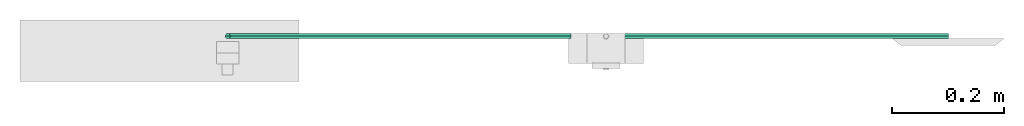
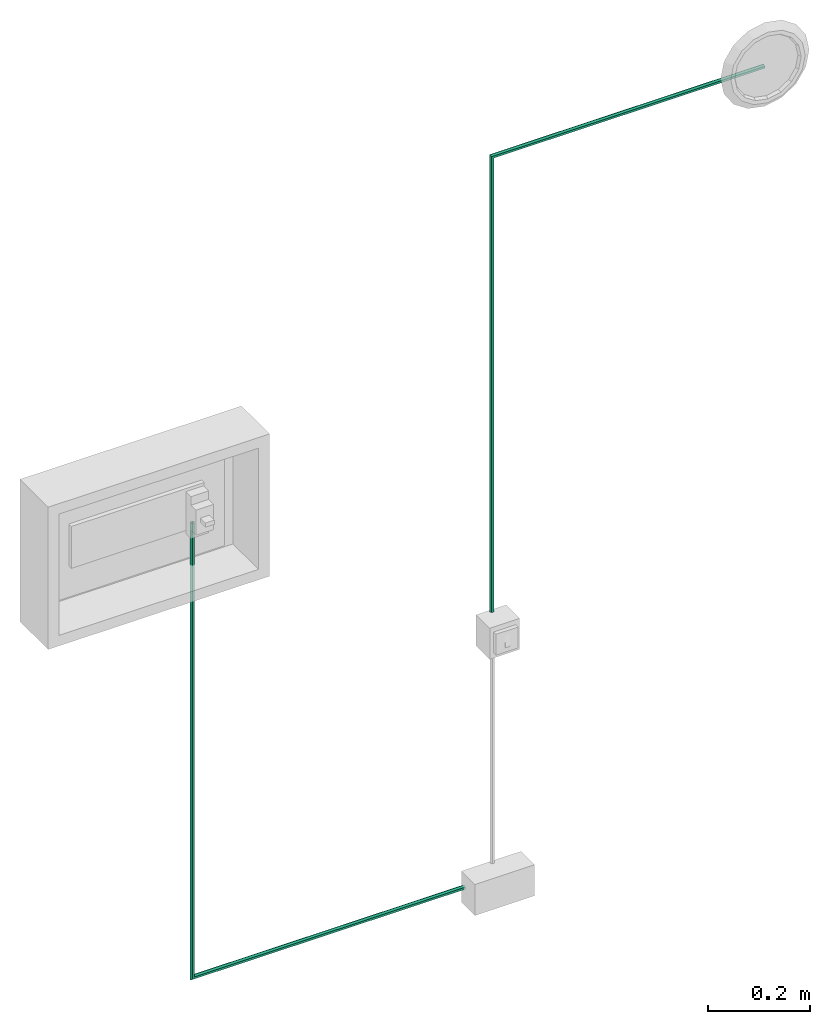
# One storey, part 2 of 4: 2 cable segments.
"""IFC4X3_ADD2 building model written with IfcOpenShell, lengths in metres."""

from ifc_helpers import new_model, entity, si_unit, converted_unit, frame, origin_with_axes, origin_2d_with_axis, place, context, subcontext, project, spatial, polygons, element, save


model = new_model("IFC4X3_ADD2")

# Units and contexts
model_context = context("Model", 3, precision=1e-05, world=origin_with_axes())
plan_context = context("Plan", 2, precision=1e-05, world=origin_2d_with_axis())
body_context = subcontext(model_context, "Body", "Model", "MODEL_VIEW")
ifc_project = project(units=[si_unit("VOLUMEUNIT", "CUBIC_METRE"), si_unit("LENGTHUNIT", "METRE"), converted_unit("PLANEANGLEUNIT", "degree", entity("IfcReal", 0.0174532925199433), si_unit("PLANEANGLEUNIT", "RADIAN"), dimensions=[0, 0, 0, 0, 0, 0, 0]), si_unit("AREAUNIT", "SQUARE_METRE")], contexts=[model_context, plan_context])

# Site, building, storey
site_placement = place(None, origin_with_axes())
site = spatial("IfcSite", under=ifc_project, at=site_placement)
building_placement = place(site_placement, origin_with_axes())
building = spatial("IfcBuilding", under=site, at=building_placement, Name="Building")
storey_placement = place(building_placement, origin_with_axes())
storey = spatial("IfcBuildingStorey", under=building, at=storey_placement, Name="Storey")

# Cable segments
for number, where, z_axis, x_axis, name in (
    (1, (0.983614861965179, 0.0896835178136826, 0.437000006437302), (0.0, -0.999999999999997, 7.54979012640431e-08), (1.0, 0.0, 0.0), "CAB-3x4"),
    (2, (1.65956807136536, 0.0896835252642632, 2.15992069244385), (0.0, 0.999999999999997, 7.54979012640431e-08), (1.0, 0.0, 0.0), "CAB-3x4"),
):
    element("IfcCableSegment", number, at=place(storey_placement, frame(where, z_axis=z_axis, x_axis=x_axis)), inside=storey, Name=name, PredefinedType="CABLESEGMENT", context=body_context, shape_type="Tessellation", body=[
        polygons([(0.00458866404369473, -0.00499999988824129, 0.0), (0.00458866357803345, -0.00249999947845936, 0.00433012703433633), (-0.612400710582733, -0.00249999947845936, 0.00433012703433633), (0.00458866357803345, 0.00249999947845936, 0.00433012703433633), (-0.607400715351105, 0.00249999947845936, 0.00433012703433633), (0.00458866311237216, 0.00499999988824129, 4.37113872875372e-10), (-0.604900717735291, 0.00499999988824129, 4.37113872875372e-10), (0.00458866357803345, 0.00250000017695129, -0.00433012703433633), (-0.607400715351105, 0.00250000017695129, -0.00433012703433633), (0.00458866357803345, -0.00249999971129, -0.00433012703433633), (-0.612400710582733, -0.00249999971129, -0.00433012703433633), (-0.614900708198547, -0.00499999988824129, 0.0), (-0.612400710582733, 1.08592069149017, 0.00433012703433633), (-0.607400715351105, 1.08592069149017, 0.00433012703433633), (-0.604900717735291, 1.08592069149017, 4.37113872875372e-10), (-0.607400715351105, 1.08592069149017, -0.00433012703433633), (-0.612400710582733, 1.08592069149017, -0.00433012703433633), (-0.614900708198547, 1.08592069149017, 0.0)], [[[1, 2, 3]], [[4, 6, 7]], [[6, 8, 9]], [[10, 1, 12]], [[12, 3, 13]], [[14, 13, 3, 2, 4, 5]], [[5, 7, 15]], [[7, 9, 16]], [[17, 16, 9, 8, 10, 11]], [[11, 12, 18]], [[3, 12, 1]], [[7, 5, 4]], [[9, 7, 6]], [[12, 11, 10]], [[13, 18, 12]], [[15, 14, 5]], [[16, 15, 7]], [[18, 17, 11]]]),
    ])

save(model, "model.ifc")
